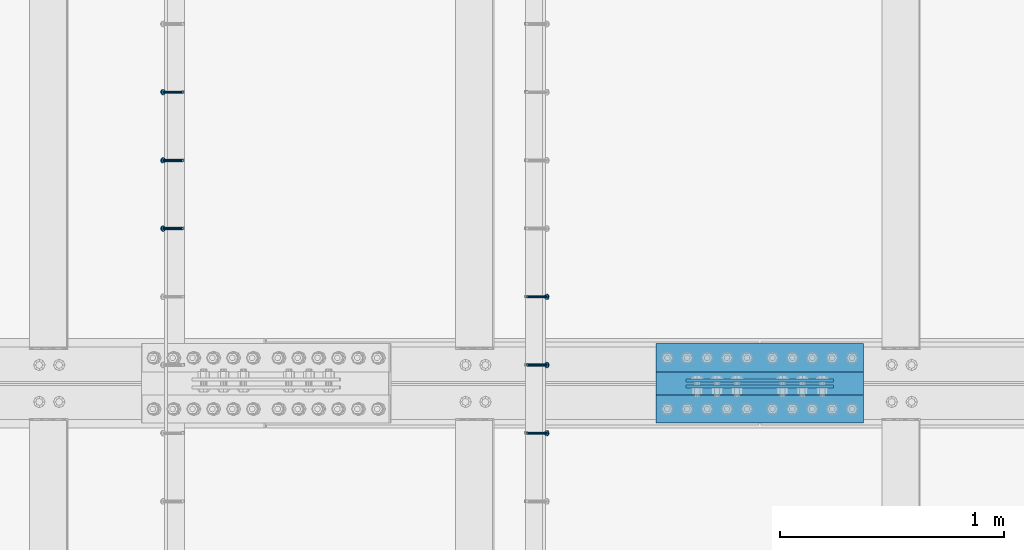
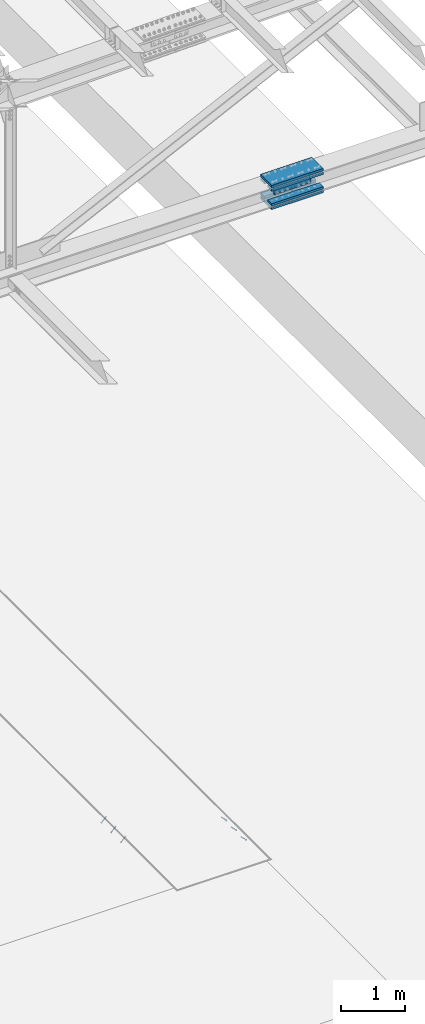
# One storey, part 2462 of 3843: 8 beams, 6 members, 3 elements without a shape of their own.
"""IFC2X3 building model written with IfcOpenShell, lengths in millimetres."""

from ifc_helpers import new_model, si_unit, frame, origin_with_axes, place, context, subcontext, project, spatial, faceted_brep, material, type_object, element, aggregate, save


model = new_model("IFC2X3")

# Units and contexts
model_context = context("Model", 3, precision=1e-05, world=origin_with_axes())
body_context = subcontext(model_context, "Body", "Model", "MODEL_VIEW")
ifc_project = project(units=[si_unit("LENGTHUNIT", "METRE", prefix="MILLI"), si_unit("AREAUNIT", "SQUARE_METRE"), si_unit("VOLUMEUNIT", "CUBIC_METRE"), si_unit("MASSUNIT", "GRAM", prefix="KILO"), si_unit("TIMEUNIT", "SECOND"), si_unit("PLANEANGLEUNIT", "RADIAN"), si_unit("SOLIDANGLEUNIT", "STERADIAN"), si_unit("THERMODYNAMICTEMPERATUREUNIT", "DEGREE_CELSIUS"), si_unit("LUMINOUSINTENSITYUNIT", "LUMEN")], contexts=[model_context])

# Site, building, storey
site_placement = place(None, origin_with_axes())
site = spatial("IfcSite", under=ifc_project, at=site_placement, CompositionType="ELEMENT")
building_placement = place(site_placement, origin_with_axes())
building = spatial("IfcBuilding", under=site, at=building_placement, Name="Undefined", CompositionType="ELEMENT")
storey_placement = place(building_placement, origin_with_axes())
storey = spatial("IfcBuildingStorey", under=building, at=storey_placement, Name="Undefined", CompositionType="ELEMENT", Elevation=0.0)

# Assembly, members
assembly_1_placement = place(storey_placement, origin_with_axes())
assembly_1 = element("IfcElementAssembly", 1, at=assembly_1_placement, inside=storey, Name="EMBED_ANGLE", AssemblyPlace="NOTDEFINED", PredefinedType="RIGID_FRAME")
ifc_material_1 = material(Name="STEEL/A108")
member_type = type_object("IfcMemberType", PredefinedType="NOTDEFINED")
member_1_placement = place(assembly_1_placement, frame((66677.3495, 67049.649703125, 30446.6625), z_axis=(0.0, 1.0, 0.0), x_axis=(0.707106781186548, 0.0, -0.707106781186548)))
member_1 = element("IfcMember", 2, at=member_1_placement, type_object=member_type, material=ifc_material_1, Name="HEADED STUD ANCHOR", context=body_context, shape_type="Brep", body=[
    faceted_brep([(7.27595761418343e-12, -3.18000006675175, 5.5), (0.0, -5.49999999998363, 3.1800000667572), (118.110000000976, -5.49999999999091, 3.1800000667572), (118.110000000983, -3.18000006675175, 5.5), (0.0, -6.3499999046162, 0.0), (118.110000000968, -6.34999990461256, 0.0), (0.0, -5.49999999998363, -3.1800000667572), (118.110000000976, -5.49999999999091, -3.1800000667572), (7.27595761418343e-12, -3.18000006675175, -5.5), (118.110000000983, -3.18000006675175, -5.5), (7.27595761418343e-12, -1.81898940354586e-12, -6.34999990463257), (118.110000000968, -1.81898940354586e-12, -6.34999990463257), (0.0, 3.18000006675175, -5.5), (118.110000000968, 3.18000006674811, -5.5), (7.27595761418343e-12, 5.49999999998363, -3.1800000667572), (118.110000000983, 5.49999999998363, -3.1800000667572), (7.27595761418343e-12, 6.3499999046162, 0.0), (118.110000000976, 6.34999990461256, 0.0), (7.27595761418343e-12, 5.49999999998363, 3.1800000667572), (118.110000000983, 5.49999999998363, 3.1800000667572), (0.0, 3.18000006675175, 5.5), (118.110000000968, 3.18000006674811, 5.5), (7.27595761418343e-12, -1.81898940354586e-12, 6.34999990463257), (118.110000000968, -1.81898940354586e-12, 6.34999990463257), (120.650000000991, -10.9899997710909, 6.34999990463257), (120.650000000998, -6.34000015257152, 10.9899997711182), (120.650000000991, -12.6999998092379, 0.0), (120.650000000991, -10.9899997710909, -6.34999990463257), (120.650000000998, -6.34000015257152, -10.9899997711182), (120.650000000991, -1.81898940354586e-12, -12.6899995803833), (120.650000000991, 6.34000015257152, -10.9899997711182), (120.650000000998, 10.9899997710909, -6.34999990463257), (120.650000000991, 12.6999998092342, 0.0), (120.650000000998, 10.9899997710909, 6.34999990463257), (120.650000000991, 6.34000015257152, 10.9899997711182), (120.650000000991, -1.81898940354586e-12, 12.6899995803833), (127.000000001048, -10.9899997710945, 6.34999990463257), (127.000000001048, -6.34000015257152, 10.9899997711182), (127.000000001048, -12.6999998092342, 0.0), (127.000000001048, -10.9899997710945, -6.34999990463257), (127.000000001048, -6.34000015257152, -10.9899997711182), (127.000000001048, 1.81898940354586e-12, -12.6899995803833), (127.000000001048, 6.34000015256788, -10.9899997711182), (127.000000001048, 10.9899997710909, -6.34999990463257), (127.000000001048, 12.6999998092379, 0.0), (127.000000001048, 10.9899997710909, 6.34999990463257), (127.000000001048, 6.34000015256788, 10.9899997711182), (127.000000001048, 1.81898940354586e-12, 12.6899995803833)], [[[0, 1, 2, 3]], [[1, 4, 5, 2]], [[4, 6, 7, 5]], [[6, 8, 9, 7]], [[8, 10, 11, 9]], [[10, 12, 13, 11]], [[12, 14, 15, 13]], [[14, 16, 17, 15]], [[16, 18, 19, 17]], [[18, 20, 21, 19]], [[20, 22, 23, 21]], [[22, 0, 3, 23]], [[22, 20, 18, 16, 14, 12, 10, 8, 6, 4, 1, 0]], [[3, 2, 24, 25]], [[2, 5, 26, 24]], [[5, 7, 27, 26]], [[7, 9, 28, 27]], [[9, 11, 29, 28]], [[11, 13, 30, 29]], [[13, 15, 31, 30]], [[15, 17, 32, 31]], [[17, 19, 33, 32]], [[19, 21, 34, 33]], [[21, 23, 35, 34]], [[23, 3, 25, 35]], [[25, 24, 36, 37]], [[24, 26, 38, 36]], [[26, 27, 39, 38]], [[27, 28, 40, 39]], [[28, 29, 41, 40]], [[29, 30, 42, 41]], [[30, 31, 43, 42]], [[31, 32, 44, 43]], [[32, 33, 45, 44]], [[33, 34, 46, 45]], [[34, 35, 47, 46]], [[35, 25, 37, 47]], [[38, 39, 40, 41, 42, 43, 44, 45, 46, 47, 37, 36]]]),
])
member_2_placement = place(assembly_1_placement, frame((66677.3495, 67354.449703125, 30446.6625), z_axis=(0.0, 1.0, 0.0), x_axis=(0.707106781186548, 0.0, -0.707106781186548)))
member_2 = element("IfcMember", 3, at=member_2_placement, type_object=member_type, material=ifc_material_1, Name="HEADED STUD ANCHOR", context=body_context, shape_type="Brep", body=[
    faceted_brep([(7.27595761418343e-12, -3.18000006675175, 5.5), (0.0, -5.49999999998363, 3.1800000667572), (118.110000000976, -5.49999999999091, 3.1800000667572), (118.110000000983, -3.18000006675175, 5.5), (0.0, -6.3499999046162, 0.0), (118.110000000968, -6.34999990461256, 0.0), (0.0, -5.49999999998363, -3.1800000667572), (118.110000000976, -5.49999999999091, -3.1800000667572), (7.27595761418343e-12, -3.18000006675175, -5.5), (118.110000000983, -3.18000006675175, -5.5), (7.27595761418343e-12, -1.81898940354586e-12, -6.34999990463257), (118.110000000968, -1.81898940354586e-12, -6.34999990463257), (0.0, 3.18000006675175, -5.5), (118.110000000968, 3.18000006674811, -5.5), (7.27595761418343e-12, 5.49999999998363, -3.1800000667572), (118.110000000983, 5.49999999998363, -3.1800000667572), (7.27595761418343e-12, 6.3499999046162, 0.0), (118.110000000976, 6.34999990461256, 0.0), (7.27595761418343e-12, 5.49999999998363, 3.1800000667572), (118.110000000983, 5.49999999998363, 3.1800000667572), (0.0, 3.18000006675175, 5.5), (118.110000000968, 3.18000006674811, 5.5), (7.27595761418343e-12, -1.81898940354586e-12, 6.34999990463257), (118.110000000968, -1.81898940354586e-12, 6.34999990463257), (120.650000000991, -10.9899997710909, 6.34999990463257), (120.650000000998, -6.34000015257152, 10.9899997711182), (120.650000000991, -12.6999998092379, 0.0), (120.650000000991, -10.9899997710909, -6.34999990463257), (120.650000000998, -6.34000015257152, -10.9899997711182), (120.650000000991, -1.81898940354586e-12, -12.6899995803833), (120.650000000991, 6.34000015257152, -10.9899997711182), (120.650000000998, 10.9899997710909, -6.34999990463257), (120.650000000991, 12.6999998092342, 0.0), (120.650000000998, 10.9899997710909, 6.34999990463257), (120.650000000991, 6.34000015257152, 10.9899997711182), (120.650000000991, -1.81898940354586e-12, 12.6899995803833), (127.000000001048, -10.9899997710945, 6.34999990463257), (127.000000001048, -6.34000015257152, 10.9899997711182), (127.000000001048, -12.6999998092342, 0.0), (127.000000001048, -10.9899997710945, -6.34999990463257), (127.000000001048, -6.34000015257152, -10.9899997711182), (127.000000001048, 1.81898940354586e-12, -12.6899995803833), (127.000000001048, 6.34000015256788, -10.9899997711182), (127.000000001048, 10.9899997710909, -6.34999990463257), (127.000000001048, 12.6999998092379, 0.0), (127.000000001048, 10.9899997710909, 6.34999990463257), (127.000000001048, 6.34000015256788, 10.9899997711182), (127.000000001048, 1.81898940354586e-12, 12.6899995803833)], [[[0, 1, 2, 3]], [[1, 4, 5, 2]], [[4, 6, 7, 5]], [[6, 8, 9, 7]], [[8, 10, 11, 9]], [[10, 12, 13, 11]], [[12, 14, 15, 13]], [[14, 16, 17, 15]], [[16, 18, 19, 17]], [[18, 20, 21, 19]], [[20, 22, 23, 21]], [[22, 0, 3, 23]], [[22, 20, 18, 16, 14, 12, 10, 8, 6, 4, 1, 0]], [[3, 2, 24, 25]], [[2, 5, 26, 24]], [[5, 7, 27, 26]], [[7, 9, 28, 27]], [[9, 11, 29, 28]], [[11, 13, 30, 29]], [[13, 15, 31, 30]], [[15, 17, 32, 31]], [[17, 19, 33, 32]], [[19, 21, 34, 33]], [[21, 23, 35, 34]], [[23, 3, 25, 35]], [[25, 24, 36, 37]], [[24, 26, 38, 36]], [[26, 27, 39, 38]], [[27, 28, 40, 39]], [[28, 29, 41, 40]], [[29, 30, 42, 41]], [[30, 31, 43, 42]], [[31, 32, 44, 43]], [[32, 33, 45, 44]], [[33, 34, 46, 45]], [[34, 35, 47, 46]], [[35, 25, 37, 47]], [[38, 39, 40, 41, 42, 43, 44, 45, 46, 47, 37, 36]]]),
])
member_3_placement = place(assembly_1_placement, frame((66677.3495, 67659.249703125, 30446.6625), z_axis=(0.0, 1.0, 0.0), x_axis=(0.707106781186548, 0.0, -0.707106781186548)))
member_3 = element("IfcMember", 4, at=member_3_placement, type_object=member_type, material=ifc_material_1, Name="HEADED STUD ANCHOR", context=body_context, shape_type="Brep", body=[
    faceted_brep([(7.27595761418343e-12, -3.18000006675175, 5.5), (0.0, -5.49999999998363, 3.1800000667572), (118.110000000976, -5.49999999999091, 3.1800000667572), (118.110000000983, -3.18000006675175, 5.5), (0.0, -6.3499999046162, 0.0), (118.110000000968, -6.34999990461256, 0.0), (0.0, -5.49999999998363, -3.1800000667572), (118.110000000976, -5.49999999999091, -3.1800000667572), (7.27595761418343e-12, -3.18000006675175, -5.5), (118.110000000983, -3.18000006675175, -5.5), (7.27595761418343e-12, -1.81898940354586e-12, -6.34999990463257), (118.110000000968, -1.81898940354586e-12, -6.34999990463257), (0.0, 3.18000006675175, -5.5), (118.110000000968, 3.18000006674811, -5.5), (7.27595761418343e-12, 5.49999999998363, -3.1800000667572), (118.110000000983, 5.49999999998363, -3.1800000667572), (7.27595761418343e-12, 6.3499999046162, 0.0), (118.110000000976, 6.34999990461256, 0.0), (7.27595761418343e-12, 5.49999999998363, 3.1800000667572), (118.110000000983, 5.49999999998363, 3.1800000667572), (0.0, 3.18000006675175, 5.5), (118.110000000968, 3.18000006674811, 5.5), (7.27595761418343e-12, -1.81898940354586e-12, 6.34999990463257), (118.110000000968, -1.81898940354586e-12, 6.34999990463257), (120.650000000991, -10.9899997710909, 6.34999990463257), (120.650000000998, -6.34000015257152, 10.9899997711182), (120.650000000991, -12.6999998092379, 0.0), (120.650000000991, -10.9899997710909, -6.34999990463257), (120.650000000998, -6.34000015257152, -10.9899997711182), (120.650000000991, -1.81898940354586e-12, -12.6899995803833), (120.650000000991, 6.34000015257152, -10.9899997711182), (120.650000000998, 10.9899997710909, -6.34999990463257), (120.650000000991, 12.6999998092342, 0.0), (120.650000000998, 10.9899997710909, 6.34999990463257), (120.650000000991, 6.34000015257152, 10.9899997711182), (120.650000000991, -1.81898940354586e-12, 12.6899995803833), (127.000000001048, -10.9899997710945, 6.34999990463257), (127.000000001048, -6.34000015257152, 10.9899997711182), (127.000000001048, -12.6999998092342, 0.0), (127.000000001048, -10.9899997710945, -6.34999990463257), (127.000000001048, -6.34000015257152, -10.9899997711182), (127.000000001048, 1.81898940354586e-12, -12.6899995803833), (127.000000001048, 6.34000015256788, -10.9899997711182), (127.000000001048, 10.9899997710909, -6.34999990463257), (127.000000001048, 12.6999998092379, 0.0), (127.000000001048, 10.9899997710909, 6.34999990463257), (127.000000001048, 6.34000015256788, 10.9899997711182), (127.000000001048, 1.81898940354586e-12, 12.6899995803833)], [[[0, 1, 2, 3]], [[1, 4, 5, 2]], [[4, 6, 7, 5]], [[6, 8, 9, 7]], [[8, 10, 11, 9]], [[10, 12, 13, 11]], [[12, 14, 15, 13]], [[14, 16, 17, 15]], [[16, 18, 19, 17]], [[18, 20, 21, 19]], [[20, 22, 23, 21]], [[22, 0, 3, 23]], [[22, 20, 18, 16, 14, 12, 10, 8, 6, 4, 1, 0]], [[3, 2, 24, 25]], [[2, 5, 26, 24]], [[5, 7, 27, 26]], [[7, 9, 28, 27]], [[9, 11, 29, 28]], [[11, 13, 30, 29]], [[13, 15, 31, 30]], [[15, 17, 32, 31]], [[17, 19, 33, 32]], [[19, 21, 34, 33]], [[21, 23, 35, 34]], [[23, 3, 25, 35]], [[25, 24, 36, 37]], [[24, 26, 38, 36]], [[26, 27, 39, 38]], [[27, 28, 40, 39]], [[28, 29, 41, 40]], [[29, 30, 42, 41]], [[30, 31, 43, 42]], [[31, 32, 44, 43]], [[32, 33, 45, 44]], [[33, 34, 46, 45]], [[34, 35, 47, 46]], [[35, 25, 37, 47]], [[38, 39, 40, 41, 42, 43, 44, 45, 46, 47, 37, 36]]]),
])
aggregate(assembly_1, [member_1, member_2, member_3])

assembly_2_placement = place(storey_placement, origin_with_axes())
assembly_2 = element("IfcElementAssembly", 5, at=assembly_2_placement, inside=storey, Name="EMBED_ANGLE", AssemblyPlace="NOTDEFINED", PredefinedType="RIGID_FRAME")
member_4_placement = place(assembly_2_placement, frame((65137.5380556641, 67964.049703125, 30446.6625), z_axis=(0.0, 1.0, 0.0), x_axis=(-0.707106781186548, 0.0, -0.707106781186548)))
member_4 = element("IfcMember", 6, at=member_4_placement, type_object=member_type, material=ifc_material_1, Name="HEADED STUD ANCHOR", context=body_context, shape_type="Brep", body=[
    faceted_brep([(7.27595761418343e-12, -3.18000006675175, 5.5), (0.0, -5.49999999998363, 3.1800000667572), (118.110000000976, -5.49999999999091, 3.1800000667572), (118.110000000983, -3.18000006675175, 5.5), (0.0, -6.3499999046162, 0.0), (118.110000000968, -6.34999990461256, 0.0), (0.0, -5.49999999998363, -3.1800000667572), (118.110000000976, -5.49999999999091, -3.1800000667572), (7.27595761418343e-12, -3.18000006675175, -5.5), (118.110000000983, -3.18000006675175, -5.5), (7.27595761418343e-12, -1.81898940354586e-12, -6.34999990463257), (118.110000000968, -1.81898940354586e-12, -6.34999990463257), (0.0, 3.18000006675175, -5.5), (118.110000000968, 3.18000006674811, -5.5), (7.27595761418343e-12, 5.49999999998363, -3.1800000667572), (118.110000000983, 5.49999999998363, -3.1800000667572), (7.27595761418343e-12, 6.3499999046162, 0.0), (118.110000000976, 6.34999990461256, 0.0), (7.27595761418343e-12, 5.49999999998363, 3.1800000667572), (118.110000000983, 5.49999999998363, 3.1800000667572), (0.0, 3.18000006675175, 5.5), (118.110000000968, 3.18000006674811, 5.5), (7.27595761418343e-12, -1.81898940354586e-12, 6.34999990463257), (118.110000000968, -1.81898940354586e-12, 6.34999990463257), (120.650000000991, -10.9899997710909, 6.34999990463257), (120.650000000998, -6.34000015257152, 10.9899997711182), (120.650000000991, -12.6999998092379, 0.0), (120.650000000991, -10.9899997710909, -6.34999990463257), (120.650000000998, -6.34000015257152, -10.9899997711182), (120.650000000991, -1.81898940354586e-12, -12.6899995803833), (120.650000000991, 6.34000015257152, -10.9899997711182), (120.650000000998, 10.9899997710909, -6.34999990463257), (120.650000000991, 12.6999998092342, 0.0), (120.650000000998, 10.9899997710909, 6.34999990463257), (120.650000000991, 6.34000015257152, 10.9899997711182), (120.650000000991, -1.81898940354586e-12, 12.6899995803833), (127.000000001048, -10.9899997710945, 6.34999990463257), (127.000000001048, -6.34000015257152, 10.9899997711182), (127.000000001048, -12.6999998092342, 0.0), (127.000000001048, -10.9899997710945, -6.34999990463257), (127.000000001048, -6.34000015257152, -10.9899997711182), (127.000000001048, 1.81898940354586e-12, -12.6899995803833), (127.000000001048, 6.34000015256788, -10.9899997711182), (127.000000001048, 10.9899997710909, -6.34999990463257), (127.000000001048, 12.6999998092379, 0.0), (127.000000001048, 10.9899997710909, 6.34999990463257), (127.000000001048, 6.34000015256788, 10.9899997711182), (127.000000001048, 1.81898940354586e-12, 12.6899995803833)], [[[0, 1, 2, 3]], [[1, 4, 5, 2]], [[4, 6, 7, 5]], [[6, 8, 9, 7]], [[8, 10, 11, 9]], [[10, 12, 13, 11]], [[12, 14, 15, 13]], [[14, 16, 17, 15]], [[16, 18, 19, 17]], [[18, 20, 21, 19]], [[20, 22, 23, 21]], [[22, 0, 3, 23]], [[22, 20, 18, 16, 14, 12, 10, 8, 6, 4, 1, 0]], [[3, 2, 24, 25]], [[2, 5, 26, 24]], [[5, 7, 27, 26]], [[7, 9, 28, 27]], [[9, 11, 29, 28]], [[11, 13, 30, 29]], [[13, 15, 31, 30]], [[15, 17, 32, 31]], [[17, 19, 33, 32]], [[19, 21, 34, 33]], [[21, 23, 35, 34]], [[23, 3, 25, 35]], [[25, 24, 36, 37]], [[24, 26, 38, 36]], [[26, 27, 39, 38]], [[27, 28, 40, 39]], [[28, 29, 41, 40]], [[29, 30, 42, 41]], [[30, 31, 43, 42]], [[31, 32, 44, 43]], [[32, 33, 45, 44]], [[33, 34, 46, 45]], [[34, 35, 47, 46]], [[35, 25, 37, 47]], [[38, 39, 40, 41, 42, 43, 44, 45, 46, 47, 37, 36]]]),
])
member_5_placement = place(assembly_2_placement, frame((65137.5380556641, 68268.849703125, 30446.6625), z_axis=(0.0, 1.0, 0.0), x_axis=(-0.707106781186548, 0.0, -0.707106781186548)))
member_5 = element("IfcMember", 7, at=member_5_placement, type_object=member_type, material=ifc_material_1, Name="HEADED STUD ANCHOR", context=body_context, shape_type="Brep", body=[
    faceted_brep([(7.27595761418343e-12, -3.18000006675175, 5.5), (0.0, -5.49999999998363, 3.1800000667572), (118.110000000976, -5.49999999999091, 3.1800000667572), (118.110000000983, -3.18000006675175, 5.5), (0.0, -6.3499999046162, 0.0), (118.110000000968, -6.34999990461256, 0.0), (0.0, -5.49999999998363, -3.1800000667572), (118.110000000976, -5.49999999999091, -3.1800000667572), (7.27595761418343e-12, -3.18000006675175, -5.5), (118.110000000983, -3.18000006675175, -5.5), (7.27595761418343e-12, -1.81898940354586e-12, -6.34999990463257), (118.110000000968, -1.81898940354586e-12, -6.34999990463257), (0.0, 3.18000006675175, -5.5), (118.110000000968, 3.18000006674811, -5.5), (7.27595761418343e-12, 5.49999999998363, -3.1800000667572), (118.110000000983, 5.49999999998363, -3.1800000667572), (7.27595761418343e-12, 6.3499999046162, 0.0), (118.110000000976, 6.34999990461256, 0.0), (7.27595761418343e-12, 5.49999999998363, 3.1800000667572), (118.110000000983, 5.49999999998363, 3.1800000667572), (0.0, 3.18000006675175, 5.5), (118.110000000968, 3.18000006674811, 5.5), (7.27595761418343e-12, -1.81898940354586e-12, 6.34999990463257), (118.110000000968, -1.81898940354586e-12, 6.34999990463257), (120.650000000991, -10.9899997710909, 6.34999990463257), (120.650000000998, -6.34000015257152, 10.9899997711182), (120.650000000991, -12.6999998092379, 0.0), (120.650000000991, -10.9899997710909, -6.34999990463257), (120.650000000998, -6.34000015257152, -10.9899997711182), (120.650000000991, -1.81898940354586e-12, -12.6899995803833), (120.650000000991, 6.34000015257152, -10.9899997711182), (120.650000000998, 10.9899997710909, -6.34999990463257), (120.650000000991, 12.6999998092342, 0.0), (120.650000000998, 10.9899997710909, 6.34999990463257), (120.650000000991, 6.34000015257152, 10.9899997711182), (120.650000000991, -1.81898940354586e-12, 12.6899995803833), (127.000000001048, -10.9899997710945, 6.34999990463257), (127.000000001048, -6.34000015257152, 10.9899997711182), (127.000000001048, -12.6999998092342, 0.0), (127.000000001048, -10.9899997710945, -6.34999990463257), (127.000000001048, -6.34000015257152, -10.9899997711182), (127.000000001048, 1.81898940354586e-12, -12.6899995803833), (127.000000001048, 6.34000015256788, -10.9899997711182), (127.000000001048, 10.9899997710909, -6.34999990463257), (127.000000001048, 12.6999998092379, 0.0), (127.000000001048, 10.9899997710909, 6.34999990463257), (127.000000001048, 6.34000015256788, 10.9899997711182), (127.000000001048, 1.81898940354586e-12, 12.6899995803833)], [[[0, 1, 2, 3]], [[1, 4, 5, 2]], [[4, 6, 7, 5]], [[6, 8, 9, 7]], [[8, 10, 11, 9]], [[10, 12, 13, 11]], [[12, 14, 15, 13]], [[14, 16, 17, 15]], [[16, 18, 19, 17]], [[18, 20, 21, 19]], [[20, 22, 23, 21]], [[22, 0, 3, 23]], [[22, 20, 18, 16, 14, 12, 10, 8, 6, 4, 1, 0]], [[3, 2, 24, 25]], [[2, 5, 26, 24]], [[5, 7, 27, 26]], [[7, 9, 28, 27]], [[9, 11, 29, 28]], [[11, 13, 30, 29]], [[13, 15, 31, 30]], [[15, 17, 32, 31]], [[17, 19, 33, 32]], [[19, 21, 34, 33]], [[21, 23, 35, 34]], [[23, 3, 25, 35]], [[25, 24, 36, 37]], [[24, 26, 38, 36]], [[26, 27, 39, 38]], [[27, 28, 40, 39]], [[28, 29, 41, 40]], [[29, 30, 42, 41]], [[30, 31, 43, 42]], [[31, 32, 44, 43]], [[32, 33, 45, 44]], [[33, 34, 46, 45]], [[34, 35, 47, 46]], [[35, 25, 37, 47]], [[38, 39, 40, 41, 42, 43, 44, 45, 46, 47, 37, 36]]]),
])
member_6_placement = place(assembly_2_placement, frame((65137.5380556641, 68573.649703125, 30446.6625), z_axis=(0.0, 1.0, 0.0), x_axis=(-0.707106781186548, 0.0, -0.707106781186548)))
member_6 = element("IfcMember", 8, at=member_6_placement, type_object=member_type, material=ifc_material_1, Name="HEADED STUD ANCHOR", context=body_context, shape_type="Brep", body=[
    faceted_brep([(7.27595761418343e-12, -3.18000006675175, 5.5), (0.0, -5.49999999998363, 3.1800000667572), (118.110000000976, -5.49999999999091, 3.1800000667572), (118.110000000983, -3.18000006675175, 5.5), (0.0, -6.3499999046162, 0.0), (118.110000000968, -6.34999990461256, 0.0), (0.0, -5.49999999998363, -3.1800000667572), (118.110000000976, -5.49999999999091, -3.1800000667572), (7.27595761418343e-12, -3.18000006675175, -5.5), (118.110000000983, -3.18000006675175, -5.5), (7.27595761418343e-12, -1.81898940354586e-12, -6.34999990463257), (118.110000000968, -1.81898940354586e-12, -6.34999990463257), (0.0, 3.18000006675175, -5.5), (118.110000000968, 3.18000006674811, -5.5), (7.27595761418343e-12, 5.49999999998363, -3.1800000667572), (118.110000000983, 5.49999999998363, -3.1800000667572), (7.27595761418343e-12, 6.3499999046162, 0.0), (118.110000000976, 6.34999990461256, 0.0), (7.27595761418343e-12, 5.49999999998363, 3.1800000667572), (118.110000000983, 5.49999999998363, 3.1800000667572), (0.0, 3.18000006675175, 5.5), (118.110000000968, 3.18000006674811, 5.5), (7.27595761418343e-12, -1.81898940354586e-12, 6.34999990463257), (118.110000000968, -1.81898940354586e-12, 6.34999990463257), (120.650000000991, -10.9899997710909, 6.34999990463257), (120.650000000998, -6.34000015257152, 10.9899997711182), (120.650000000991, -12.6999998092379, 0.0), (120.650000000991, -10.9899997710909, -6.34999990463257), (120.650000000998, -6.34000015257152, -10.9899997711182), (120.650000000991, -1.81898940354586e-12, -12.6899995803833), (120.650000000991, 6.34000015257152, -10.9899997711182), (120.650000000998, 10.9899997710909, -6.34999990463257), (120.650000000991, 12.6999998092342, 0.0), (120.650000000998, 10.9899997710909, 6.34999990463257), (120.650000000991, 6.34000015257152, 10.9899997711182), (120.650000000991, -1.81898940354586e-12, 12.6899995803833), (127.000000001048, -10.9899997710945, 6.34999990463257), (127.000000001048, -6.34000015257152, 10.9899997711182), (127.000000001048, -12.6999998092342, 0.0), (127.000000001048, -10.9899997710945, -6.34999990463257), (127.000000001048, -6.34000015257152, -10.9899997711182), (127.000000001048, 1.81898940354586e-12, -12.6899995803833), (127.000000001048, 6.34000015256788, -10.9899997711182), (127.000000001048, 10.9899997710909, -6.34999990463257), (127.000000001048, 12.6999998092379, 0.0), (127.000000001048, 10.9899997710909, 6.34999990463257), (127.000000001048, 6.34000015256788, 10.9899997711182), (127.000000001048, 1.81898940354586e-12, 12.6899995803833)], [[[0, 1, 2, 3]], [[1, 4, 5, 2]], [[4, 6, 7, 5]], [[6, 8, 9, 7]], [[8, 10, 11, 9]], [[10, 12, 13, 11]], [[12, 14, 15, 13]], [[14, 16, 17, 15]], [[16, 18, 19, 17]], [[18, 20, 21, 19]], [[20, 22, 23, 21]], [[22, 0, 3, 23]], [[22, 20, 18, 16, 14, 12, 10, 8, 6, 4, 1, 0]], [[3, 2, 24, 25]], [[2, 5, 26, 24]], [[5, 7, 27, 26]], [[7, 9, 28, 27]], [[9, 11, 29, 28]], [[11, 13, 30, 29]], [[13, 15, 31, 30]], [[15, 17, 32, 31]], [[17, 19, 33, 32]], [[19, 21, 34, 33]], [[21, 23, 35, 34]], [[23, 3, 25, 35]], [[25, 24, 36, 37]], [[24, 26, 38, 36]], [[26, 27, 39, 38]], [[27, 28, 40, 39]], [[28, 29, 41, 40]], [[29, 30, 42, 41]], [[30, 31, 43, 42]], [[31, 32, 44, 43]], [[32, 33, 45, 44]], [[33, 34, 46, 45]], [[34, 35, 47, 46]], [[35, 25, 37, 47]], [[38, 39, 40, 41, 42, 43, 44, 45, 46, 47, 37, 36]]]),
])
aggregate(assembly_2, [member_4, member_5, member_6])

# Assembly, beams
assembly_3_placement = place(storey_placement, origin_with_axes())
assembly_3 = element("IfcElementAssembly", 9, at=assembly_3_placement, inside=storey, Name="BEAM", AssemblyPlace="NOTDEFINED", PredefinedType="RIGID_FRAME")
ifc_material_2 = material(Name="STEEL/A572-50")
beam_type_1 = type_object("IfcBeamType", PredefinedType="NOTDEFINED")
beam_1_placement = place(assembly_3_placement, frame((68046.6000810881, 67285.3937469886, 42344.4680728876), z_axis=(-0.000175717999925837, 0.0, 0.999999984561592), x_axis=(-0.999999984561592, 0.0, -0.000175717999926746)))
beam_1 = element("IfcBeam", 10, at=beam_1_placement, type_object=beam_type_1, material=ifc_material_2, Name="PLATE", context=body_context, shape_type="Brep", body=[
    faceted_brep([(1.45519152283669e-11, 6.35000000000582, -88.8999999998996), (0.0, 6.34999999999854, 88.9000015258789), (660.399999982677, 6.35000000000582, 88.8999999999651), (660.399999982707, 6.35000000000582, -88.8999999998268), (0.0, -6.34999999999854, 88.9000015258789), (660.399999982677, -6.35000000000582, 88.8999999999651), (1.45519152283669e-11, -6.35000000000582, -88.8999999998996), (660.399999982707, -6.35000000000582, -88.8999999998268)], [[[0, 1, 2, 3]], [[1, 4, 5, 2]], [[4, 6, 7, 5]], [[6, 0, 3, 7]], [[5, 7, 3, 2]], [[6, 4, 1, 0]]]),
])
beam_2_placement = place(assembly_3_placement, frame((68046.6000810881, 67258.4062469886, 42344.4680728876), z_axis=(-0.000175717999925837, 0.0, 0.999999984561592), x_axis=(-0.999999984561592, 0.0, -0.000175717999926746)))
beam_2 = element("IfcBeam", 11, at=beam_2_placement, type_object=beam_type_1, material=ifc_material_2, Name="PLATE", context=body_context, shape_type="Brep", body=[
    faceted_brep([(1.45519152283669e-11, 6.35000000000582, -88.8999999998996), (0.0, 6.34999999999854, 88.9000015258789), (660.399999982677, 6.35000000000582, 88.8999999999651), (660.399999982707, 6.35000000000582, -88.8999999998268), (0.0, -6.34999999999854, 88.9000015258789), (660.399999982677, -6.35000000000582, 88.8999999999651), (1.45519152283669e-11, -6.35000000000582, -88.8999999998996), (660.399999982707, -6.35000000000582, -88.8999999998268)], [[[0, 1, 2, 3]], [[1, 4, 5, 2]], [[4, 6, 7, 5]], [[6, 0, 3, 7]], [[5, 7, 3, 2]], [[6, 4, 1, 0]]]),
])
beam_type_2 = type_object("IfcBeamType", PredefinedType="NOTDEFINED")
beam_3_placement = place(assembly_3_placement, frame((68179.9138154135, 67271.8999969886, 42550.8656880278), z_axis=(0.0, 1.0, 0.0), x_axis=(-0.999999984561592, 0.0, -0.000175717999926746)))
beam_3 = element("IfcBeam", 12, at=beam_3_placement, type_object=beam_type_2, material=ifc_material_2, Name="PLATE", context=body_context, shape_type="Brep", body=[
    faceted_brep([(0.0, 22.2249999999767, -177.800000000003), (0.0, 22.2249999999767, 177.800000000003), (927.099999958984, 22.2250000000859, 177.800000000003), (927.099999958984, 22.2250000000859, -177.800000000003), (0.0, -22.2249999999694, 177.800000000003), (927.099999958984, -22.2249999998749, 177.800000000003), (0.0, -22.2249999999694, -177.800000000003), (927.099999958984, -22.2249999998749, -177.800000000003)], [[[0, 1, 2, 3]], [[1, 4, 5, 2]], [[4, 6, 7, 5]], [[6, 0, 3, 7]], [[5, 7, 3, 2]], [[6, 4, 1, 0]]]),
])
beam_4_placement = place(assembly_3_placement, frame((68179.9914684774, 67271.8999969886, 42138.0375627187), z_axis=(0.0, 1.0, 0.0), x_axis=(-0.999999984561592, 0.0, -0.000175717999926746)))
beam_4 = element("IfcBeam", 13, at=beam_4_placement, type_object=beam_type_2, material=ifc_material_2, Name="PLATE", context=body_context, shape_type="Brep", body=[
    faceted_brep([(0.0, 22.2249999999767, -177.800000000003), (0.0, 22.2249999999767, 177.800000000003), (927.099999958984, 22.2250000000859, 177.800000000003), (927.099999958984, 22.2250000000859, -177.800000000003), (0.0, -22.2249999999694, 177.800000000003), (927.099999958984, -22.2249999998749, 177.800000000003), (0.0, -22.2249999999694, -177.800000000003), (927.099999958984, -22.2249999998749, -177.800000000003)], [[[0, 1, 2, 3]], [[1, 4, 5, 2]], [[4, 6, 7, 5]], [[6, 0, 3, 7]], [[5, 7, 3, 2]], [[6, 4, 1, 0]]]),
])
beam_type_3 = type_object("IfcBeamType", PredefinedType="NOTDEFINED")
beam_5_placement = place(assembly_3_placement, frame((67252.8743739742, 67386.1999969886, 42206.1489393872), z_axis=(0.0, 1.0, 0.0), x_axis=(0.999999984561592, 0.0, 0.00017571799991991)))
beam_5 = element("IfcBeam", 14, at=beam_5_placement, type_object=beam_type_3, material=ifc_material_2, Name="PLATE", context=body_context, shape_type="Brep", body=[
    faceted_brep([(-7.27595761418343e-11, 22.2250000000786, -63.5), (-7.27595761418343e-11, 22.2250000000786, 63.5), (927.099999951592, 22.2250000031054, 63.5), (927.099999951592, 22.2250000031054, -63.5), (6.54836185276508e-11, -22.2250000000713, 63.5), (927.099999951744, -22.2249999970372, 63.5), (6.54836185276508e-11, -22.2250000000713, -63.5), (927.099999951744, -22.2249999970372, -63.5)], [[[0, 1, 2, 3]], [[1, 4, 5, 2]], [[4, 6, 7, 5]], [[6, 0, 3, 7]], [[5, 7, 3, 2]], [[6, 4, 1, 0]]]),
])
beam_6_placement = place(assembly_3_placement, frame((67252.8258383971, 67157.5999969886, 42482.3621494376), z_axis=(0.0, 1.0, 0.0), x_axis=(0.999999984561592, 0.0, 0.00017571799991991)))
beam_6 = element("IfcBeam", 15, at=beam_6_placement, type_object=beam_type_3, material=ifc_material_2, Name="PLATE", context=body_context, shape_type="Brep", body=[
    faceted_brep([(-7.27595761418343e-11, 22.2250000000786, -63.5), (-7.27595761418343e-11, 22.2250000000786, 63.5), (927.099999951592, 22.2250000031054, 63.5), (927.099999951592, 22.2250000031054, -63.5), (6.54836185276508e-11, -22.2250000000713, 63.5), (927.099999951744, -22.2249999970372, 63.5), (6.54836185276508e-11, -22.2250000000713, -63.5), (927.099999951744, -22.2249999970372, -63.5)], [[[0, 1, 2, 3]], [[1, 4, 5, 2]], [[4, 6, 7, 5]], [[6, 0, 3, 7]], [[5, 7, 3, 2]], [[6, 4, 1, 0]]]),
])
beam_7_placement = place(assembly_3_placement, frame((67252.8258383971, 67386.1999969886, 42482.3621494376), z_axis=(0.0, 1.0, 0.0), x_axis=(0.999999984561592, 0.0, 0.00017571799991991)))
beam_7 = element("IfcBeam", 16, at=beam_7_placement, type_object=beam_type_3, material=ifc_material_2, Name="PLATE", context=body_context, shape_type="Brep", body=[
    faceted_brep([(-7.27595761418343e-11, 22.2250000000786, -63.5), (-7.27595761418343e-11, 22.2250000000786, 63.5), (927.099999951592, 22.2250000031054, 63.5), (927.099999951592, 22.2250000031054, -63.5), (6.54836185276508e-11, -22.2250000000713, 63.5), (927.099999951744, -22.2249999970372, 63.5), (6.54836185276508e-11, -22.2250000000713, -63.5), (927.099999951744, -22.2249999970372, -63.5)], [[[0, 1, 2, 3]], [[1, 4, 5, 2]], [[4, 6, 7, 5]], [[6, 0, 3, 7]], [[5, 7, 3, 2]], [[6, 4, 1, 0]]]),
])
beam_8_placement = place(assembly_3_placement, frame((67252.8743739742, 67157.5999969886, 42206.1489393872), z_axis=(0.0, 1.0, 0.0), x_axis=(0.999999984561592, 0.0, 0.00017571799991991)))
beam_8 = element("IfcBeam", 17, at=beam_8_placement, type_object=beam_type_3, material=ifc_material_2, Name="PLATE", context=body_context, shape_type="Brep", body=[
    faceted_brep([(-7.27595761418343e-11, 22.2250000000786, -63.5), (-7.27595761418343e-11, 22.2250000000786, 63.5), (927.099999951592, 22.2250000031054, 63.5), (927.099999951592, 22.2250000031054, -63.5), (6.54836185276508e-11, -22.2250000000713, 63.5), (927.099999951744, -22.2249999970372, 63.5), (6.54836185276508e-11, -22.2250000000713, -63.5), (927.099999951744, -22.2249999970372, -63.5)], [[[0, 1, 2, 3]], [[1, 4, 5, 2]], [[4, 6, 7, 5]], [[6, 0, 3, 7]], [[5, 7, 3, 2]], [[6, 4, 1, 0]]]),
])
aggregate(assembly_3, [beam_1, beam_3, beam_5, beam_6, beam_7, beam_8, beam_4, beam_2])

save(model, "model.ifc")
